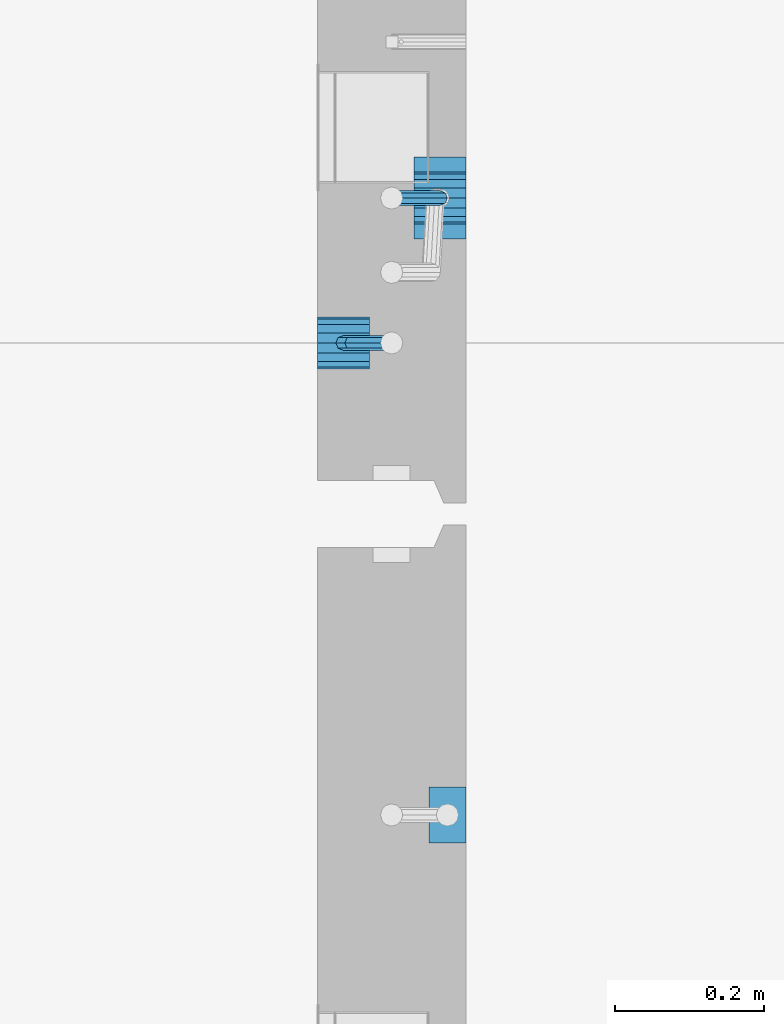
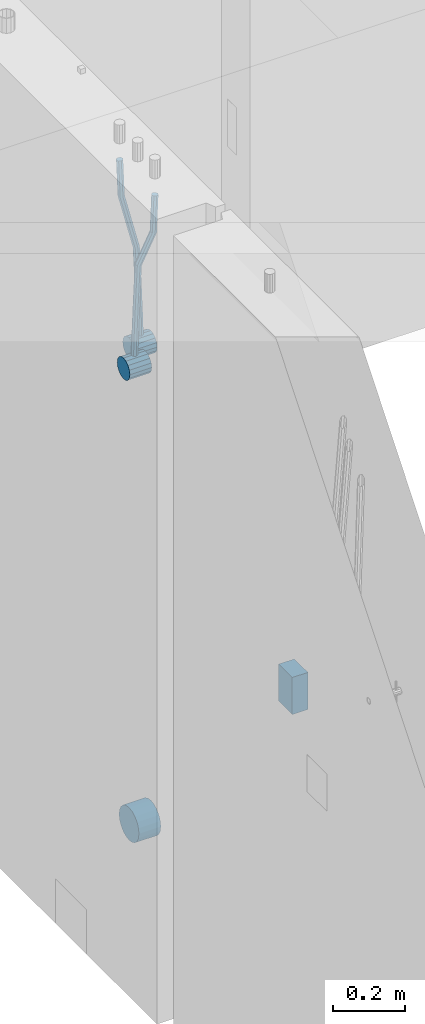
# One storey, part 143 of 341: 6 beams, 2 elements without a shape of their own.
"""IFC2X3 building model written with IfcOpenShell, lengths in millimetres."""

from ifc_helpers import new_model, si_unit, frame, origin_with_axes, place, context, subcontext, project, spatial, faceted_brep, material, type_object, element, aggregate, save


model = new_model("IFC2X3")

# Units and contexts
model_context = context("Model", 3, precision=1e-05, world=origin_with_axes())
body_context = subcontext(model_context, "Body", "Model", "MODEL_VIEW")
ifc_project = project(units=[si_unit("LENGTHUNIT", "METRE", prefix="MILLI"), si_unit("AREAUNIT", "SQUARE_METRE"), si_unit("VOLUMEUNIT", "CUBIC_METRE"), si_unit("MASSUNIT", "GRAM", prefix="KILO"), si_unit("TIMEUNIT", "SECOND"), si_unit("PLANEANGLEUNIT", "RADIAN"), si_unit("SOLIDANGLEUNIT", "STERADIAN"), si_unit("THERMODYNAMICTEMPERATUREUNIT", "DEGREE_CELSIUS"), si_unit("LUMINOUSINTENSITYUNIT", "LUMEN")], contexts=[model_context])

# Site, building, storey
site_placement = place(None, origin_with_axes())
site = spatial("IfcSite", under=ifc_project, at=site_placement, CompositionType="ELEMENT")
building_placement = place(site_placement, origin_with_axes())
building = spatial("IfcBuilding", under=site, at=building_placement, CompositionType="ELEMENT")
storey_placement = place(building_placement, origin_with_axes())
storey = spatial("IfcBuildingStorey", under=building, at=storey_placement, Name="5", CompositionType="ELEMENT", Elevation=0.0)

# Assembly, beams
assembly_1_placement = place(storey_placement, origin_with_axes())
assembly_1 = element("IfcElementAssembly", 1, at=assembly_1_placement, inside=storey, AssemblyPlace="NOTDEFINED", PredefinedType="REINFORCEMENT_UNIT")
ifc_material = material()
beam_type_1 = type_object("IfcBeamType", Name="D20", PredefinedType="NOTDEFINED")
beam_1_placement = place(assembly_1_placement, frame((21875.0000022791, 12925.0000000039, 95795.0), z_axis=(-0.999642804636942, -0.000205726999925762, -0.0267249099902983), x_axis=(-0.0267249099948371, 4.30000201934385e-08, 0.999642825806181)))
beam_1 = element("IfcBeam", 2, at=beam_1_placement, type_object=beam_type_1, material=ifc_material, Name="JM20", ObjectType="D20", context=body_context, shape_type="Brep", body=[
    faceted_brep([(0.0, -10.0, 0.0), (-4.19531716033816e-08, -7.07106781186667, -7.07106781187031), (60.4266690400545, -7.0710677960451, -7.07106780570757), (60.4266690441291, -9.99999998418934, 6.15546014159918e-09), (0.0, 0.0, -10.0), (60.426669036824, 1.58106558956206e-08, -9.99999999384454), (4.196772351861e-08, 7.07106781186303, -7.07106781186667), (60.4266690363438, 7.07106782768096, -7.07106780570757), (0.0, 10.0, 0.0), (60.4266690388904, 10.0000000158179, 6.15182216279209e-09), (4.196772351861e-08, 7.07106781185939, 7.07106781185939), (60.4266690429649, 7.07106782768096, 7.07106781802577), (0.0, 0.0, 10.0), (60.4266690461809, 1.58179318532348e-08, 10.0000000061555), (-4.19531716033816e-08, -7.07106781187031, 7.07106781185939), (60.4266690466611, -7.07106779605238, 7.07106781802213), (61.0378400410118, -7.07106779588503, -7.07106780564936), (60.991799419251, -9.99999998403655, 6.21366780251265e-09), (61.0569027789461, 1.5985278878361e-08, -9.99999999378269), (61.0378209396877, 7.07106782784831, -7.07106780564936), (60.9917724058905, 10.0000000159635, 6.21366780251265e-09), (60.9457317841297, 7.07106782781193, 7.0710678180767), (60.9266690461809, 1.59488990902901e-08, 10.0000000062028), (60.9457508854539, -7.07106779591413, 7.0710678180767), (61.6489592143771, -7.07106614513759, -7.06310863441468), (61.5568818710308, -9.9999984576425, 0.00735959856683621), (61.6870830769039, 1.71821739058942e-06, -9.99179257185824), (61.6489210170112, 7.07106947854481, -7.06310888312146), (61.556827851804, 10.0000015422847, 0.00735924683976918), (61.4647505084577, 7.07106922979438, 7.07782747982128), (61.4266266459163, 1.36643211590126e-06, 10.0065114172685), (61.464788705809, -7.07106639389531, 7.07782772852806), (176.543135720174, -7.07075579406956, -5.56673531796696), (176.451058376813, -9.99968810657447, 1.50373291501455), (176.581259582701, 0.000312069292704109, -8.49541925541052), (176.543097522794, 7.07137982961285, -5.56673556667374), (176.451004357587, 10.00031189336, 1.50373256329476), (176.35892701424, 7.07137958085514, 8.57420079627263), (176.320803151699, 0.000311717507429421, 11.5028847337162), (176.358965211621, -7.07075604281999, 8.57420104497578), (177.098753836006, -7.07075429323595, -5.55949898843028), (176.98362511232, -9.99968666800123, 1.510669025065), (177.146421932586, 0.000313595905026887, -8.48805862247536), (177.098706077581, 7.07138133041735, -5.55949936166144), (176.983557571715, 10.0003133318824, 1.51066849724157), (176.868428848029, 7.07138095712435, 8.58083651073321), (176.820760751449, 0.000313067976094317, 11.5093961447819), (176.868476606425, -7.07075466652896, 8.58083688396073), (177.654312950661, -7.07075204110879, -5.54863964998367), (177.516135294456, -9.99968450931192, 1.52107783331303), (177.711524267797, 0.000315886711177882, -8.47701274570863), (177.654255632195, 7.07138358250813, -5.54864021007961), (177.516054233929, 10.0003154905207, 1.5210770412159), (177.377876577739, 7.0713830223176, 8.59079452451624), (177.320665260588, 0.000315094497636892, 11.5191676202448), (177.377933896176, -7.07075260129932, 8.59079508461218), (298.592214475648, -7.07025824167067, -3.18470470795364), (298.454036904819, -9.99919071054683, 3.88501277673276), (298.649425586758, 0.000809686429420253, -6.11307780703646), (298.592156745173, 7.07187738194261, -3.18470527475802), (298.453955261604, 10.0008092892858, 3.88501197515143), (298.315777690761, 7.07187682041331, 10.9547294598378), (298.258566579665, 0.000808892309578368, 13.883102558917), (298.31583542125, -7.07025880319998, 10.9547300266422), (300.829882012156, -7.07024910539985, -3.14096572775816), (299.972022738802, -9.99918451269514, 3.91468436611831), (301.18507173346, 0.000820039333120803, -6.0635143331092), (300.829526581147, 7.07188651699835, -3.14097211362241), (299.971520083447, 10.0008154854204, 3.91467533514515), (299.113660810108, 7.07188007812692, 10.9703254290253), (298.758471088819, 0.000810933392131119, 13.8928740343799), (299.114016241103, -7.07025554427128, 10.9703318148859), (303.012825988379, -7.0701468967527, -2.64717965084128), (301.452885279024, -9.99911517653163, 4.24965828764471), (303.65870706641, 0.000935858577577164, -5.50397331873319), (303.012180137302, 7.07198871204673, -2.64725173027909), (301.451971907663, 10.0008848023517, 4.24955635192964), (299.892031198324, 7.07191652257279, 11.1463942904193), (299.246150120278, 0.000833767242511385, 14.0031879583075), (299.892677049385, -7.07021908622846, 11.1464663698534), (490.480206458145, -7.06136939830685, 39.7582981627347), (488.920265748791, -9.9903376780876, 46.6551361012243), (491.126087536177, 0.00971335702342913, 36.9015044948464), (490.479560607055, 7.0807662104944, 39.7582260832969), (488.91935237743, 10.0096623007976, 46.6550341655056), (487.359411668076, 7.08069402101864, 53.5518721039953), (486.713530590045, 0.00961126568654436, 56.4086657718872), (487.360057519167, -7.06144158778261, 53.5519441834331), (491.222094319732, -7.06133466202664, 39.9261146072568), (490.367102775039, -9.9902699350514, 46.9824133868096), (491.613766567636, 0.0097361908719904, 37.0118184187741), (491.312683227967, 7.08080521851844, 39.9466800038063), (490.495214837676, 10.0097360849959, 47.0114972495248), (489.640223292983, 7.08080081197113, 54.0677960290814), (489.248551045079, 0.00972995907250152, 56.9820922175604), (489.549634384748, -7.06133906857212, 54.0472306325282), (491.98259360576, -7.07125184727738, 39.9362361015701), (491.850235984879, -10.009610527557, 47.0021524248696), (492.113679795017, 0.00321714190249622, 37.0184717700395), (492.166706040836, 7.06966845271199, 39.958046203883), (492.110610287549, 9.988670745126, 47.0329965673554), (491.978252666668, 7.05031206484455, 54.0989128906476), (491.847166477397, -0.0241569243353297, 57.0166772221819), (491.794140231592, -7.09060823514483, 54.077102788342), (512.839684553823, -7.34323584322192, 40.2138233804726), (512.707326932941, -10.2815945235034, 47.2797397037684), (512.970770743079, -0.268766854042042, 37.296059048942), (513.023796988884, 6.79768445676746, 40.2356334827819), (512.967701235597, 9.71668674918146, 47.3105838462543), (512.83534361473, 6.77832806890183, 54.3765001695538), (512.704257425459, -0.296140920279868, 57.2942645010808), (512.651231179654, -7.36259223108937, 54.3546900672372), (513.475042066755, -7.35152113457298, 40.2222793613946), (513.367413171509, -10.2902022863618, 47.2885247996019), (513.548971693657, -0.276306803183616, 37.3037543324754), (513.545895079456, 6.79087610917486, 40.2425820926655), (513.467614462992, 9.71016770021379, 47.3172371975234), (513.359985567746, 6.77148654842495, 54.3834826357306), (513.286055940844, -0.303727782968053, 57.3020076646499), (513.289132555044, -7.37091069532653, 54.3631799044524), (514.110453382629, -7.34964673829199, 40.2305416874733), (514.027555144421, -10.2882337755309, 47.2971163788461), (514.127221878356, -0.274611275939606, 37.3112548247955), (514.06803787424, 6.7924127919523, 40.249334442502), (513.967570557215, 9.71165861202826, 47.3236933478729), (513.884672319007, 6.77307157479117, 54.3902680392421), (513.867903823266, -0.301963887563034, 57.3095549019235), (513.927087827382, -7.36898795545494, 54.3714752842207), (614.131240716772, -7.05138387012084, 41.5279197320488), (614.048342478563, -9.98997090735793, 48.5944944234179), (614.148009212484, 0.0236515922315448, 38.6086328693636), (614.088825208368, 7.09067566012527, 41.5467124870702), (613.988357891343, 10.0099214802012, 48.6210713924484), (613.905459653135, 7.07133444296232, 55.6876460838175), (613.888691157408, -0.00370101939006418, 58.606932946499), (613.947875161524, -7.07072508728379, 55.6688533287888)], [[[0, 1, 2, 3]], [[1, 4, 5, 2]], [[4, 6, 7, 5]], [[6, 8, 9, 7]], [[8, 10, 11, 9]], [[10, 12, 13, 11]], [[12, 14, 15, 13]], [[14, 0, 3, 15]], [[14, 12, 10, 8, 6, 4, 1, 0]], [[3, 2, 16, 17]], [[2, 5, 18, 16]], [[5, 7, 19, 18]], [[7, 9, 20, 19]], [[9, 11, 21, 20]], [[11, 13, 22, 21]], [[13, 15, 23, 22]], [[15, 3, 17, 23]], [[17, 16, 24, 25]], [[16, 18, 26, 24]], [[18, 19, 27, 26]], [[19, 20, 28, 27]], [[20, 21, 29, 28]], [[21, 22, 30, 29]], [[22, 23, 31, 30]], [[23, 17, 25, 31]], [[25, 24, 32, 33]], [[24, 26, 34, 32]], [[26, 27, 35, 34]], [[27, 28, 36, 35]], [[28, 29, 37, 36]], [[29, 30, 38, 37]], [[30, 31, 39, 38]], [[31, 25, 33, 39]], [[33, 32, 40, 41]], [[32, 34, 42, 40]], [[34, 35, 43, 42]], [[35, 36, 44, 43]], [[36, 37, 45, 44]], [[37, 38, 46, 45]], [[38, 39, 47, 46]], [[39, 33, 41, 47]], [[41, 40, 48, 49]], [[40, 42, 50, 48]], [[42, 43, 51, 50]], [[43, 44, 52, 51]], [[44, 45, 53, 52]], [[45, 46, 54, 53]], [[46, 47, 55, 54]], [[47, 41, 49, 55]], [[49, 48, 56, 57]], [[48, 50, 58, 56]], [[50, 51, 59, 58]], [[51, 52, 60, 59]], [[52, 53, 61, 60]], [[53, 54, 62, 61]], [[54, 55, 63, 62]], [[55, 49, 57, 63]], [[57, 56, 64, 65]], [[56, 58, 66, 64]], [[58, 59, 67, 66]], [[59, 60, 68, 67]], [[60, 61, 69, 68]], [[61, 62, 70, 69]], [[62, 63, 71, 70]], [[63, 57, 65, 71]], [[65, 64, 72, 73]], [[64, 66, 74, 72]], [[66, 67, 75, 74]], [[67, 68, 76, 75]], [[68, 69, 77, 76]], [[69, 70, 78, 77]], [[70, 71, 79, 78]], [[71, 65, 73, 79]], [[73, 72, 80, 81]], [[72, 74, 82, 80]], [[74, 75, 83, 82]], [[75, 76, 84, 83]], [[76, 77, 85, 84]], [[77, 78, 86, 85]], [[78, 79, 87, 86]], [[79, 73, 81, 87]], [[81, 80, 88, 89]], [[80, 82, 90, 88]], [[82, 83, 91, 90]], [[83, 84, 92, 91]], [[84, 85, 93, 92]], [[85, 86, 94, 93]], [[86, 87, 95, 94]], [[87, 81, 89, 95]], [[89, 88, 96, 97]], [[88, 90, 98, 96]], [[90, 91, 99, 98]], [[91, 92, 100, 99]], [[92, 93, 101, 100]], [[93, 94, 102, 101]], [[94, 95, 103, 102]], [[95, 89, 97, 103]], [[97, 96, 104, 105]], [[96, 98, 106, 104]], [[98, 99, 107, 106]], [[99, 100, 108, 107]], [[100, 101, 109, 108]], [[101, 102, 110, 109]], [[102, 103, 111, 110]], [[103, 97, 105, 111]], [[105, 104, 112, 113]], [[104, 106, 114, 112]], [[106, 107, 115, 114]], [[107, 108, 116, 115]], [[108, 109, 117, 116]], [[109, 110, 118, 117]], [[110, 111, 119, 118]], [[111, 105, 113, 119]], [[113, 112, 120, 121]], [[112, 114, 122, 120]], [[114, 115, 123, 122]], [[115, 116, 124, 123]], [[116, 117, 125, 124]], [[117, 118, 126, 125]], [[118, 119, 127, 126]], [[119, 113, 121, 127]], [[121, 120, 128, 129]], [[120, 122, 130, 128]], [[122, 123, 131, 130]], [[123, 124, 132, 131]], [[124, 125, 133, 132]], [[125, 126, 134, 133]], [[126, 127, 135, 134]], [[127, 121, 129, 135]], [[130, 131, 132, 133, 134, 135, 129, 128]]]),
])
beam_2_placement = place(assembly_1_placement, frame((21744.9999977209, 12729.9999999961, 95890.0), z_axis=(0.999642804629538, 0.000205762999925497, -0.0267249099901003), x_axis=(0.0267249109941254, -4.30000210532798e-08, 0.999642825779465)))
beam_2 = element("IfcBeam", 3, at=beam_2_placement, type_object=beam_type_1, material=ifc_material, Name="JM20", ObjectType="D20", context=body_context, shape_type="Brep", body=[
    faceted_brep([(0.0, -10.0, 0.0), (-4.19531716033816e-08, -7.07106781186667, -7.07106781187031), (60.4266690400545, -7.0710677960451, -7.07106780570757), (60.4266690441291, -9.99999998418934, 6.15546014159918e-09), (0.0, 0.0, -10.0), (60.426669036824, 1.58106558956206e-08, -9.99999999384454), (4.196772351861e-08, 7.07106781186303, -7.07106781186667), (60.4266690363438, 7.07106782768096, -7.07106780570757), (0.0, 10.0, 0.0), (60.4266690388904, 10.0000000158179, 6.15182216279209e-09), (4.196772351861e-08, 7.07106781185939, 7.07106781185939), (60.4266690429649, 7.07106782768096, 7.07106781802577), (0.0, 0.0, 10.0), (60.4266690461809, 1.58179318532348e-08, 10.0000000061555), (-4.19531716033816e-08, -7.07106781187031, 7.07106781185939), (60.4266690466611, -7.07106779605238, 7.07106781802213), (61.0378400410118, -7.07106779588503, -7.07106780564936), (60.991799419251, -9.99999998403655, 6.21366780251265e-09), (61.0569027789461, 1.5985278878361e-08, -9.99999999378269), (61.0378209396877, 7.07106782784831, -7.07106780564936), (60.9917724058905, 10.0000000159635, 6.21366780251265e-09), (60.9457317841297, 7.07106782781193, 7.0710678180767), (60.9266690461809, 1.59488990902901e-08, 10.0000000062028), (60.9457508854539, -7.07106779591413, 7.0710678180767), (61.6489592143771, -7.07106614513759, -7.06310863441468), (61.5568818710308, -9.9999984576425, 0.00735959856683621), (61.6870830769039, 1.71821739058942e-06, -9.99179257185824), (61.6489210170112, 7.07106947854481, -7.06310888312146), (61.556827851804, 10.0000015422847, 0.00735924683976918), (61.4647505084577, 7.07106922979438, 7.07782747982128), (61.4266266459163, 1.36643211590126e-06, 10.0065114172685), (61.464788705809, -7.07106639389531, 7.07782772852806), (176.543135720174, -7.07075579406956, -5.56673531796696), (176.451058376813, -9.99968810657447, 1.50373291501455), (176.581259582701, 0.000312069292704109, -8.49541925541052), (176.543097522794, 7.07137982961285, -5.56673556667374), (176.451004357587, 10.00031189336, 1.50373256329476), (176.35892701424, 7.07137958085514, 8.57420079627263), (176.320803151699, 0.000311717507429421, 11.5028847337162), (176.358965211621, -7.07075604281999, 8.57420104497578), (177.098753836006, -7.07075429323595, -5.55949898843028), (176.98362511232, -9.99968666800123, 1.510669025065), (177.146421932586, 0.000313595905026887, -8.48805862247536), (177.098706077581, 7.07138133041735, -5.55949936166144), (176.983557571715, 10.0003133318824, 1.51066849724157), (176.868428848029, 7.07138095712435, 8.58083651073321), (176.820760751449, 0.000313067976094317, 11.5093961447819), (176.868476606425, -7.07075466652896, 8.58083688396073), (177.654312950661, -7.07075204110879, -5.54863964998367), (177.516135294456, -9.99968450931192, 1.52107783331303), (177.711524267797, 0.000315886711177882, -8.47701274570863), (177.654255632195, 7.07138358250813, -5.54864021007961), (177.516054233929, 10.0003154905207, 1.5210770412159), (177.377876577739, 7.0713830223176, 8.59079452451624), (177.320665260588, 0.000315094497636892, 11.5191676202448), (177.377933896176, -7.07075260129932, 8.59079508461218), (297.446964549832, -7.07026642590426, -3.20709054437975), (297.308786893627, -9.99919889410376, 3.86262693891331), (297.504175866998, 0.000801501919340808, -6.13546364010836), (297.44690723141, 7.07186919770902, -3.20709110447569), (297.308705833115, 10.0008011057289, 3.86262614682164), (297.170528176895, 7.07186863752577, 10.9323436301165), (297.113316859759, 0.000800709702161839, 13.8607167258415), (297.170585495318, -7.07026698608752, 10.9323441902106), (301.63986343499, -7.07024942873613, -3.12513327486886), (299.972259732356, -9.99918809692099, 3.91468900081236), (302.330321453323, 0.000821066147182137, -6.04112849743797), (301.639172844472, 7.07188619231601, -3.12514621333321), (299.971283089879, 10.0008118992846, 3.91467070306135), (298.303679387245, 7.07187323109611, 10.9544929787371), (297.613221368898, 0.000802736216428457, 13.870488201308), (298.304369977734, -7.0702623899524, 10.9545059172033), (305.4239078393, -7.06987516590743, -1.31733741553398), (302.376014215231, -9.99895035236841, 5.06306278734701), (306.685863931343, 0.00125185327851796, -3.96030416885333), (305.422645727784, 7.07226039861052, -1.31762339341367), (302.374229320019, 10.0010495638962, 5.06265835355225), (299.326335695951, 7.07197437743162, 11.4430585564332), (298.064379603893, 0.000847358245664509, 14.0860253097508), (299.327597807453, -7.07016118708634, 11.4433445343111), (396.081143409523, -7.0609086662007, 41.9934056867296), (393.033249785469, -9.98998385266168, 48.3738058896106), (397.34309950161, 0.0102183529888862, 39.3504389334103), (396.079881298036, 7.08122689832453, 41.9931197088481), (393.031464890271, 10.0100160636066, 48.3734014558122), (389.983571266188, 7.08094087714562, 54.753801658695), (388.72161517413, 0.00981385795967071, 57.3967684120162), (389.984833377704, -7.06119468737961, 54.7540876365765), (397.068790959223, -7.06081098241702, 42.4652461198857), (395.403898118791, -9.98974938248648, 49.5063634875187), (397.79425773659, 0.0102629750217602, 39.565976041853), (397.155329851754, 7.08133326610914, 42.5069063441551), (395.526282594277, 10.0102628148125, 49.5652799416912), (393.861389753831, 7.08132441474299, 56.606397309326), (393.135922976478, 0.0102504573078477, 59.5056673873569), (393.774850861315, -7.06081983378317, 56.5647370850584), (398.163169908337, -7.0750819080713, 42.4798112226927), (398.030733605352, -10.0240038552729, 49.541324073105), (398.294170965004, 0.00374400413056719, 39.572629393122), (398.346998133013, 7.06579366763617, 42.5227662718698), (398.290705973835, 9.97421416771613, 49.6020716862276), (398.15826967085, 7.02529222051089, 56.6635845366436), (398.027268614198, -0.0535336916836968, 59.5707663662142), (397.974441446175, -7.11558335519294, 56.6206294874646), (417.87389934808, -7.33211385723553, 42.7421415616409), (417.741463045095, -10.2810358044335, 49.803654412055), (418.004900404732, -0.253287945030024, 39.8349597320685), (418.057727572756, 6.8087617184683, 42.7850966108181), (418.001435413564, 9.71718221855917, 49.8644020251777), (417.868999110593, 6.76826027135394, 56.92591487559), (417.737998053926, -0.310565640847926, 59.8330967051625), (417.685170885918, -7.37261530435353, 56.8829598264128), (418.509166047603, -7.3403978651113, 42.7505963339045), (418.401542092906, -10.2896433704191, 49.812439412166), (418.582978010687, -0.260826195415575, 39.8426533739894), (418.579739935274, 6.80195457034279, 42.7920440797316), (418.501348641992, 9.71066324766434, 49.8710553764413), (418.393724687281, 6.76141774235657, 56.9328984547028), (418.319912724211, -0.318153927339154, 59.8408414146197), (418.323150799639, -7.38093469310479, 56.8914507088775), (419.144486528079, -7.33852513420788, 42.7588588031304), (419.061676848418, -10.2876749343814, 49.821032815089), (419.161104845465, -0.25913295731516, 39.8501522177412), (419.101797015624, 6.80348967242753, 42.7987939276718), (419.00130476091, 9.71215420445515, 49.8775096098252), (418.918495081249, 6.76300440428531, 56.9396836217802), (418.901876763863, -0.316387772607413, 59.8483902071712), (418.961184593718, -7.37901040236102, 56.8997484972406), (519.165277458538, -7.04026297675227, 44.0562368946885), (519.082467778877, -9.98941277692575, 51.1184109066417), (519.181895775939, 0.0391292001404508, 41.1475303092957), (519.122587946098, 7.10175182989406, 44.0961720192245), (519.022095691384, 10.0104163619108, 51.1748877013797), (518.939286011722, 7.06126656174456, 58.2370617133347), (518.922667694336, -0.0181256151481648, 61.1457682987275), (518.981975524162, -7.08074824490541, 58.1971265887951)], [[[0, 1, 2, 3]], [[1, 4, 5, 2]], [[4, 6, 7, 5]], [[6, 8, 9, 7]], [[8, 10, 11, 9]], [[10, 12, 13, 11]], [[12, 14, 15, 13]], [[14, 0, 3, 15]], [[14, 12, 10, 8, 6, 4, 1, 0]], [[3, 2, 16, 17]], [[2, 5, 18, 16]], [[5, 7, 19, 18]], [[7, 9, 20, 19]], [[9, 11, 21, 20]], [[11, 13, 22, 21]], [[13, 15, 23, 22]], [[15, 3, 17, 23]], [[17, 16, 24, 25]], [[16, 18, 26, 24]], [[18, 19, 27, 26]], [[19, 20, 28, 27]], [[20, 21, 29, 28]], [[21, 22, 30, 29]], [[22, 23, 31, 30]], [[23, 17, 25, 31]], [[25, 24, 32, 33]], [[24, 26, 34, 32]], [[26, 27, 35, 34]], [[27, 28, 36, 35]], [[28, 29, 37, 36]], [[29, 30, 38, 37]], [[30, 31, 39, 38]], [[31, 25, 33, 39]], [[33, 32, 40, 41]], [[32, 34, 42, 40]], [[34, 35, 43, 42]], [[35, 36, 44, 43]], [[36, 37, 45, 44]], [[37, 38, 46, 45]], [[38, 39, 47, 46]], [[39, 33, 41, 47]], [[41, 40, 48, 49]], [[40, 42, 50, 48]], [[42, 43, 51, 50]], [[43, 44, 52, 51]], [[44, 45, 53, 52]], [[45, 46, 54, 53]], [[46, 47, 55, 54]], [[47, 41, 49, 55]], [[49, 48, 56, 57]], [[48, 50, 58, 56]], [[50, 51, 59, 58]], [[51, 52, 60, 59]], [[52, 53, 61, 60]], [[53, 54, 62, 61]], [[54, 55, 63, 62]], [[55, 49, 57, 63]], [[57, 56, 64, 65]], [[56, 58, 66, 64]], [[58, 59, 67, 66]], [[59, 60, 68, 67]], [[60, 61, 69, 68]], [[61, 62, 70, 69]], [[62, 63, 71, 70]], [[63, 57, 65, 71]], [[65, 64, 72, 73]], [[64, 66, 74, 72]], [[66, 67, 75, 74]], [[67, 68, 76, 75]], [[68, 69, 77, 76]], [[69, 70, 78, 77]], [[70, 71, 79, 78]], [[71, 65, 73, 79]], [[73, 72, 80, 81]], [[72, 74, 82, 80]], [[74, 75, 83, 82]], [[75, 76, 84, 83]], [[76, 77, 85, 84]], [[77, 78, 86, 85]], [[78, 79, 87, 86]], [[79, 73, 81, 87]], [[81, 80, 88, 89]], [[80, 82, 90, 88]], [[82, 83, 91, 90]], [[83, 84, 92, 91]], [[84, 85, 93, 92]], [[85, 86, 94, 93]], [[86, 87, 95, 94]], [[87, 81, 89, 95]], [[89, 88, 96, 97]], [[88, 90, 98, 96]], [[90, 91, 99, 98]], [[91, 92, 100, 99]], [[92, 93, 101, 100]], [[93, 94, 102, 101]], [[94, 95, 103, 102]], [[95, 89, 97, 103]], [[97, 96, 104, 105]], [[96, 98, 106, 104]], [[98, 99, 107, 106]], [[99, 100, 108, 107]], [[100, 101, 109, 108]], [[101, 102, 110, 109]], [[102, 103, 111, 110]], [[103, 97, 105, 111]], [[105, 104, 112, 113]], [[104, 106, 114, 112]], [[106, 107, 115, 114]], [[107, 108, 116, 115]], [[108, 109, 117, 116]], [[109, 110, 118, 117]], [[110, 111, 119, 118]], [[111, 105, 113, 119]], [[113, 112, 120, 121]], [[112, 114, 122, 120]], [[114, 115, 123, 122]], [[115, 116, 124, 123]], [[116, 117, 125, 124]], [[117, 118, 126, 125]], [[118, 119, 127, 126]], [[119, 113, 121, 127]], [[121, 120, 128, 129]], [[120, 122, 130, 128]], [[122, 123, 131, 130]], [[123, 124, 132, 131]], [[124, 125, 133, 132]], [[125, 126, 134, 133]], [[126, 127, 135, 134]], [[127, 121, 129, 135]], [[130, 131, 132, 133, 134, 135, 129, 128]]]),
])
beam_type_2 = type_object("IfcBeamType", Name="D70", PredefinedType="NOTDEFINED")
beam_3_placement = place(assembly_1_placement, frame((21839.9999977209, 12925.0, 95760.0), z_axis=(0.0, 0.0, 1.0), x_axis=(1.0, 0.0, 0.0)))
beam_3 = element("IfcBeam", 4, at=beam_3_placement, type_object=beam_type_2, material=ifc_material, ObjectType="D70", context=body_context, shape_type="Brep", body=[
    faceted_brep([(0.0, -35.0, 0.0), (0.0, -32.3357836378964, -13.3939201327739), (70.0, -32.3357836378964, -13.3939201327739), (70.0, -35.0, 0.0), (0.0, -24.7487373415279, -24.7487373415352), (70.0, -24.7487373415279, -24.7487373415352), (0.0, -13.3939201327776, -32.3357836379), (70.0, -13.3939201327776, -32.3357836379), (0.0, 0.0, -35.0), (70.0, 0.0, -35.0), (0.0, 13.3939201327776, -32.3357836379), (70.0, 13.3939201327776, -32.3357836379), (0.0, 24.7487373415279, -24.7487373415352), (70.0, 24.7487373415279, -24.7487373415352), (0.0, 32.3357836378964, -13.3939201327739), (70.0, 32.3357836378964, -13.3939201327739), (0.0, 35.0, 0.0), (70.0, 35.0, 0.0), (0.0, 32.3357836378964, 13.3939201327739), (70.0, 32.3357836378964, 13.3939201327739), (0.0, 24.7487373415279, 24.7487373415352), (70.0, 24.7487373415279, 24.7487373415352), (0.0, 13.3939201327776, 32.3357836379), (70.0, 13.3939201327776, 32.3357836379), (0.0, 0.0, 35.0), (70.0, 0.0, 35.0), (0.0, -13.3939201327776, 32.3357836379), (70.0, -13.3939201327776, 32.3357836379), (0.0, -24.7487373415279, 24.7487373415352), (70.0, -24.7487373415279, 24.7487373415352), (0.0, -32.3357836378964, 13.3939201327739), (70.0, -32.3357836378964, 13.3939201327739)], [[[0, 1, 2, 3]], [[1, 4, 5, 2]], [[4, 6, 7, 5]], [[6, 8, 9, 7]], [[8, 10, 11, 9]], [[10, 12, 13, 11]], [[12, 14, 15, 13]], [[14, 16, 17, 15]], [[16, 18, 19, 17]], [[18, 20, 21, 19]], [[20, 22, 23, 21]], [[22, 24, 25, 23]], [[24, 26, 27, 25]], [[26, 28, 29, 27]], [[28, 30, 31, 29]], [[30, 0, 3, 31]], [[5, 7, 9, 11, 13, 15, 17, 19, 21, 23, 25, 27, 29, 31, 3, 2]], [[30, 28, 26, 24, 22, 20, 18, 16, 14, 12, 10, 8, 6, 4, 1, 0]]]),
])
beam_4_placement = place(assembly_1_placement, frame((21709.9999977209, 12730.0, 95855.0), z_axis=(0.0, 0.0, 1.0), x_axis=(1.0, 0.0, 0.0)))
beam_4 = element("IfcBeam", 5, at=beam_4_placement, type_object=beam_type_2, material=ifc_material, ObjectType="D70", context=body_context, shape_type="Brep", body=[
    faceted_brep([(0.0, -35.0, 0.0), (0.0, -32.3357836378964, -13.3939201327739), (70.0, -32.3357836378964, -13.3939201327739), (70.0, -35.0, 0.0), (0.0, -24.7487373415279, -24.7487373415352), (70.0, -24.7487373415279, -24.7487373415352), (0.0, -13.3939201327776, -32.3357836379), (70.0, -13.3939201327776, -32.3357836379), (0.0, 0.0, -35.0), (70.0, 0.0, -35.0), (0.0, 13.3939201327776, -32.3357836379), (70.0, 13.3939201327776, -32.3357836379), (0.0, 24.7487373415279, -24.7487373415352), (70.0, 24.7487373415279, -24.7487373415352), (0.0, 32.3357836378964, -13.3939201327739), (70.0, 32.3357836378964, -13.3939201327739), (0.0, 35.0, 0.0), (70.0, 35.0, 0.0), (0.0, 32.3357836378964, 13.3939201327739), (70.0, 32.3357836378964, 13.3939201327739), (0.0, 24.7487373415279, 24.7487373415352), (70.0, 24.7487373415279, 24.7487373415352), (0.0, 13.3939201327776, 32.3357836379), (70.0, 13.3939201327776, 32.3357836379), (0.0, 0.0, 35.0), (70.0, 0.0, 35.0), (0.0, -13.3939201327776, 32.3357836379), (70.0, -13.3939201327776, 32.3357836379), (0.0, -24.7487373415279, 24.7487373415352), (70.0, -24.7487373415279, 24.7487373415352), (0.0, -32.3357836378964, 13.3939201327739), (70.0, -32.3357836378964, 13.3939201327739)], [[[0, 1, 2, 3]], [[1, 4, 5, 2]], [[4, 6, 7, 5]], [[6, 8, 9, 7]], [[8, 10, 11, 9]], [[10, 12, 13, 11]], [[12, 14, 15, 13]], [[14, 16, 17, 15]], [[16, 18, 19, 17]], [[18, 20, 21, 19]], [[20, 22, 23, 21]], [[22, 24, 25, 23]], [[24, 26, 27, 25]], [[26, 28, 29, 27]], [[28, 30, 31, 29]], [[30, 0, 3, 31]], [[5, 7, 9, 11, 13, 15, 17, 19, 21, 23, 25, 27, 29, 31, 3, 2]], [[30, 28, 26, 24, 22, 20, 18, 16, 14, 12, 10, 8, 6, 4, 1, 0]]]),
])
beam_type_3 = type_object("IfcBeamType", Name="D110", PredefinedType="NOTDEFINED")
beam_5_placement = place(assembly_1_placement, frame((21910.0000022791, 12925.0, 94155.0), z_axis=(0.0, 0.0, 1.0), x_axis=(-1.0, 3.00000001838171e-08, 0.0)))
beam_5 = element("IfcBeam", 6, at=beam_5_placement, type_object=beam_type_3, material=ifc_material, ObjectType="D110", context=body_context, shape_type="Brep", body=[
    faceted_brep([(0.0, -55.0, 0.0), (0.0, -52.3081083962352, -16.9959346906253), (70.0, -52.3081083962352, -16.9959346906253), (70.0, -55.0, 0.0), (0.0, -44.4959346906217, -32.328188876083), (70.0, -44.4959346906217, -32.328188876083), (0.0, -32.3281888760866, -44.4959346906253), (70.0, -32.3281888760866, -44.4959346906253), (0.0, -16.9959346906217, -52.3081083962315), (70.0, -16.9959346906217, -52.3081083962315), (0.0, 0.0, -55.0), (70.0, 0.0, -55.0), (0.0, 16.9959346906217, -52.3081083962315), (70.0, 16.9959346906217, -52.3081083962315), (0.0, 32.3281888760866, -44.4959346906253), (70.0, 32.3281888760866, -44.4959346906253), (0.0, 44.4959346906217, -32.328188876083), (70.0, 44.4959346906217, -32.328188876083), (0.0, 52.3081083962352, -16.9959346906253), (70.0, 52.3081083962352, -16.9959346906253), (0.0, 55.0, 0.0), (70.0, 55.0, 0.0), (0.0, 52.3081083962352, 16.9959346906253), (70.0, 52.3081083962352, 16.9959346906253), (0.0, 44.4959346906217, 32.328188876083), (70.0, 44.4959346906217, 32.328188876083), (0.0, 32.3281888760866, 44.4959346906253), (70.0, 32.3281888760866, 44.4959346906253), (0.0, 16.9959346906217, 52.3081083962315), (70.0, 16.9959346906217, 52.3081083962315), (0.0, 0.0, 55.0), (70.0, 0.0, 55.0), (0.0, -16.9959346906217, 52.3081083962315), (70.0, -16.9959346906217, 52.3081083962315), (0.0, -32.3281888760866, 44.4959346906253), (70.0, -32.3281888760866, 44.4959346906253), (0.0, -44.4959346906217, 32.328188876083), (70.0, -44.4959346906217, 32.328188876083), (0.0, -52.3081083962352, 16.9959346906253), (70.0, -52.3081083962352, 16.9959346906253)], [[[0, 1, 2, 3]], [[1, 4, 5, 2]], [[4, 6, 7, 5]], [[6, 8, 9, 7]], [[8, 10, 11, 9]], [[10, 12, 13, 11]], [[12, 14, 15, 13]], [[14, 16, 17, 15]], [[16, 18, 19, 17]], [[18, 20, 21, 19]], [[20, 22, 23, 21]], [[22, 24, 25, 23]], [[24, 26, 27, 25]], [[26, 28, 29, 27]], [[28, 30, 31, 29]], [[30, 32, 33, 31]], [[32, 34, 35, 33]], [[34, 36, 37, 35]], [[36, 38, 39, 37]], [[38, 0, 3, 39]], [[5, 7, 9, 11, 13, 15, 17, 19, 21, 23, 25, 27, 29, 31, 33, 35, 37, 39, 3, 2]], [[38, 36, 34, 32, 30, 28, 26, 24, 22, 20, 18, 16, 14, 12, 10, 8, 6, 4, 1, 0]]]),
])
aggregate(assembly_1, [beam_1, beam_3, beam_2, beam_4, beam_5])

# Assembly, beam
assembly_2_placement = place(storey_placement, origin_with_axes())
assembly_2 = element("IfcElementAssembly", 7, at=assembly_2_placement, inside=storey, AssemblyPlace="NOTDEFINED", PredefinedType="REINFORCEMENT_UNIT")
beam_type_4 = type_object("IfcBeamType", Name="125X50", PredefinedType="NOTDEFINED")
beam_6_placement = place(assembly_2_placement, frame((21885.0, 12057.5, 95105.0), z_axis=(0.0, 0.0, 1.0), x_axis=(0.0, 1.0, 0.0)))
beam_6 = element("IfcBeam", 8, at=beam_6_placement, type_object=beam_type_4, material=ifc_material, Name="WM1", ObjectType="125X50", context=body_context, shape_type="Brep", body=[
    faceted_brep([(0.0, 25.0, -62.5), (0.0, 25.0, 62.5), (75.0, 25.0, 62.5), (75.0, 25.0, -62.5), (0.0, -25.0, 62.5), (75.0, -25.0, 62.5), (0.0, -25.0, -62.5), (75.0, -25.0, -62.5)], [[[0, 1, 2, 3]], [[1, 4, 5, 2]], [[4, 6, 7, 5]], [[6, 0, 3, 7]], [[5, 7, 3, 2]], [[0, 6, 4, 1]]]),
])
aggregate(assembly_2, [beam_6])

save(model, "model.ifc")
